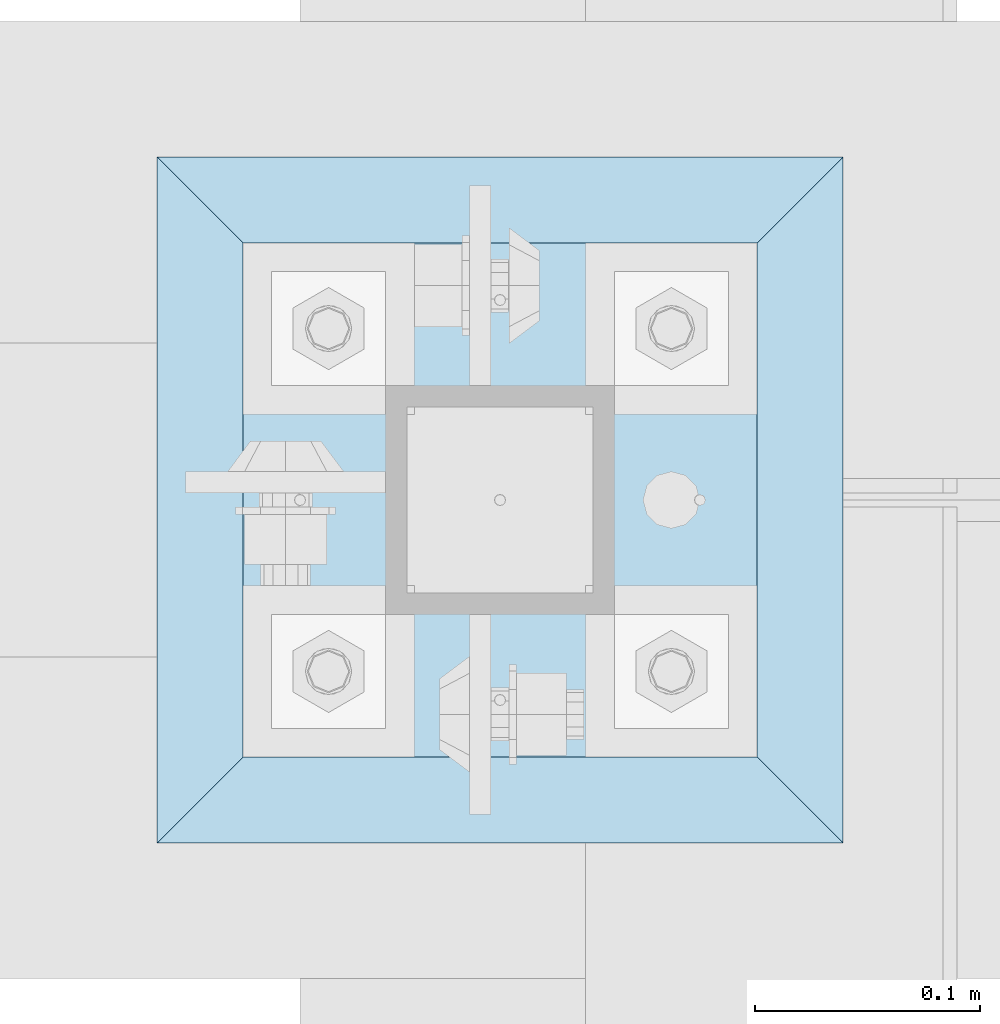
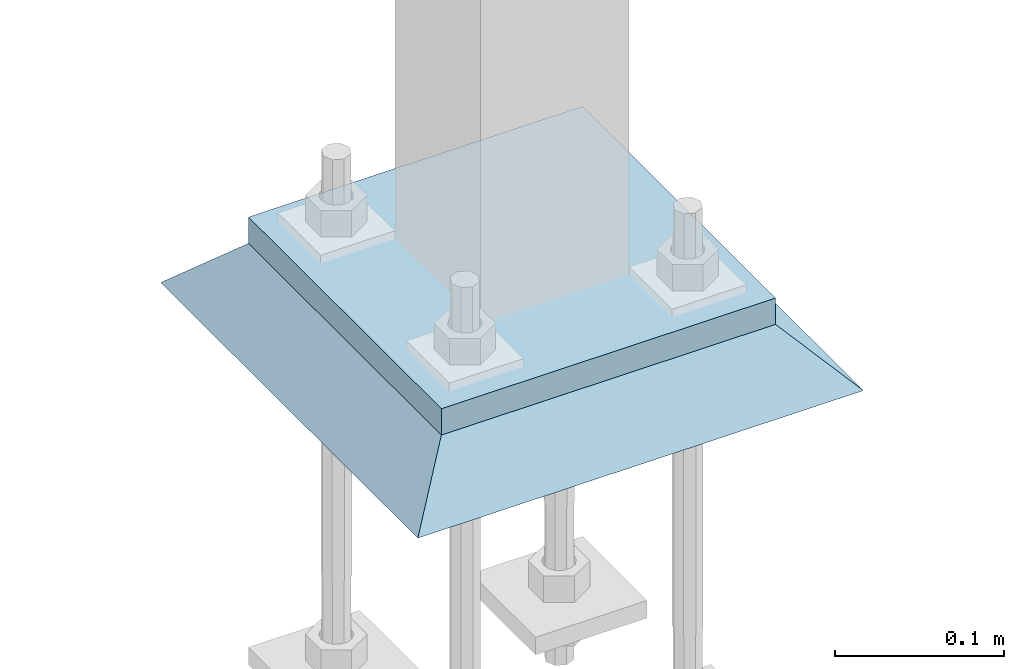
# One storey, part 3261 of 3843: 2 plates, 2 elements without a shape of their own.
"""IFC2X3 building model written with IfcOpenShell, lengths in millimetres."""

from ifc_helpers import new_model, si_unit, frame, origin_with_axes, place, context, subcontext, project, spatial, faceted_brep, material, type_object, element, aggregate, save


model = new_model("IFC2X3")

# Units and contexts
model_context = context("Model", 3, precision=1e-05, world=origin_with_axes())
body_context = subcontext(model_context, "Body", "Model", "MODEL_VIEW")
ifc_project = project(units=[si_unit("LENGTHUNIT", "METRE", prefix="MILLI"), si_unit("AREAUNIT", "SQUARE_METRE"), si_unit("VOLUMEUNIT", "CUBIC_METRE"), si_unit("MASSUNIT", "GRAM", prefix="KILO"), si_unit("TIMEUNIT", "SECOND"), si_unit("PLANEANGLEUNIT", "RADIAN"), si_unit("SOLIDANGLEUNIT", "STERADIAN"), si_unit("THERMODYNAMICTEMPERATUREUNIT", "DEGREE_CELSIUS"), si_unit("LUMINOUSINTENSITYUNIT", "LUMEN")], contexts=[model_context])

# Site, building, storey
site_placement = place(None, origin_with_axes())
site = spatial("IfcSite", under=ifc_project, at=site_placement, CompositionType="ELEMENT")
building_placement = place(site_placement, origin_with_axes())
building = spatial("IfcBuilding", under=site, at=building_placement, Name="Undefined", CompositionType="ELEMENT")
storey_placement = place(building_placement, origin_with_axes())
storey = spatial("IfcBuildingStorey", under=building, at=storey_placement, Name="Undefined", CompositionType="ELEMENT", Elevation=0.0)

# Assembly, plate
assembly_1_placement = place(storey_placement, origin_with_axes())
assembly_1 = element("IfcElementAssembly", 1, at=assembly_1_placement, inside=storey, Name="COLUMN", AssemblyPlace="NOTDEFINED", PredefinedType="RIGID_FRAME")
ifc_material_1 = material(Name="STEEL/A572-50")
plate_type_1 = type_object("IfcPlateType", PredefinedType="NOTDEFINED")
plate_1_placement = place(assembly_1_placement, frame((38706.425, 50444.4, 30070.425), z_axis=(0.0, 1.0, 0.0), x_axis=(1.0, 0.0, 0.0)))
plate_1 = element("IfcPlate", 2, at=plate_1_placement, type_object=plate_type_1, material=ifc_material_1, Name="PLATE", context=body_context, shape_type="Brep", body=[
    faceted_brep([(0.0, -9.52500000000146, 0.0), (0.0, -9.52500000000146, 228.600006103516), (0.0, 9.52500000000146, 228.600006103516), (0.0, 9.52500000000146, 0.0), (228.600006103516, -9.52500000000146, 228.600006103516), (228.600006103516, 9.52500000000146, 228.600006103516), (228.599999999999, -9.52500000000146, 0.0), (228.599999999999, 9.52500000000146, 0.0)], [[[0, 1, 2, 3]], [[1, 4, 5, 2]], [[4, 6, 7, 5]], [[6, 0, 3, 7]], [[5, 7, 3, 2]], [[6, 4, 1, 0]]]),
])
aggregate(assembly_1, [plate_1])

assembly_2_placement = place(storey_placement, origin_with_axes())
assembly_2 = element("IfcElementAssembly", 3, at=assembly_2_placement, inside=storey, Name="GROUT", AssemblyPlace="NOTDEFINED", PredefinedType="REINFORCEMENT_UNIT")
ifc_material_2 = material(Name="CONCRETE/Concrete_Undefined")
plate_type_2 = type_object("IfcPlateType", PredefinedType="NOTDEFINED")
plate_2_placement = place(assembly_2_placement, frame((38668.325, 50406.3, 30041.85), z_axis=(0.0, 1.0, 0.0), x_axis=(1.0, 0.0, 0.0)))
plate_2 = element("IfcPlate", 4, at=plate_2_placement, type_object=plate_type_2, material=ifc_material_2, Name="GROUT", context=body_context, shape_type="Brep", body=[
    faceted_brep([(38.0999999997875, -19.0499999997883, 266.699999999328), (0.0, 19.0499999999993, 304.799987792969), (0.0, 19.0500000000029, 0.0), (38.1000000006916, -19.0499999999811, 38.1000000006607), (266.700000000201, -19.0499999998174, 38.1000000006752), (304.799987792969, 19.0499999999993, 0.0), (304.799987792969, 19.0499999999993, 304.799987792969), (266.700000000201, -19.0499999999738, 266.699999999328)], [[[0, 1, 2, 3]], [[4, 5, 6, 7]], [[4, 7, 0, 3]], [[5, 4, 3, 2]], [[6, 5, 2, 1]], [[7, 6, 1, 0]]]),
])
aggregate(assembly_2, [plate_2])

save(model, "model.ifc")
